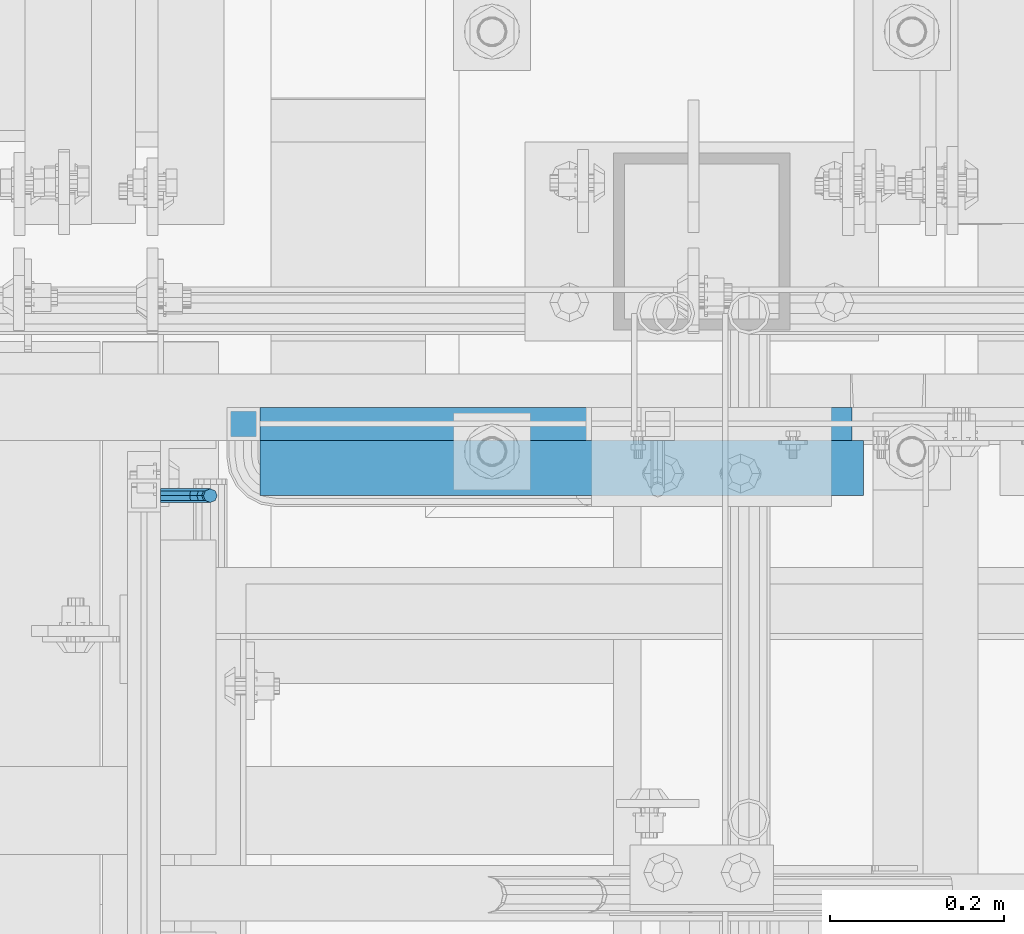
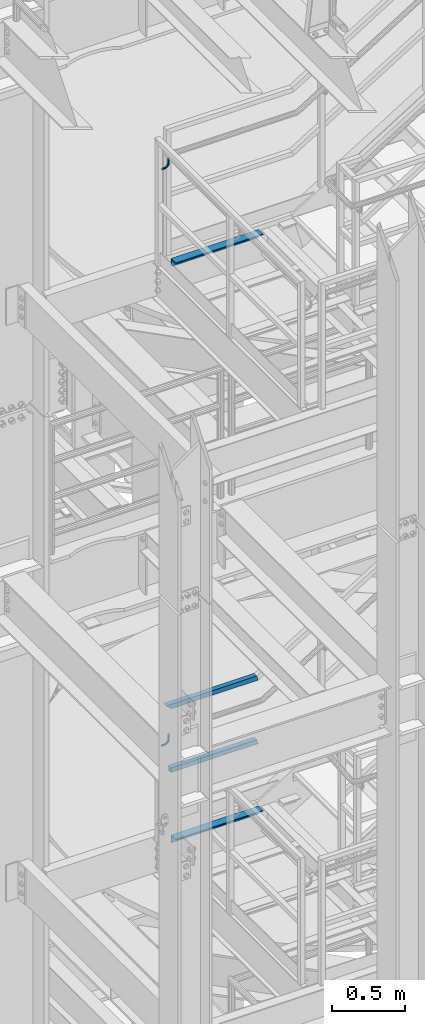
# One storey, part 1164 of 1876: 6 beams, 5 elements without a shape of their own.
"""IFC2X3 building model written with IfcOpenShell, lengths in millimetres."""

import ifcopenshell
import ifcopenshell.guid

model = None  # the IFC model being written
_history = None  # IfcOwnerHistory: only IFC2X3 demands one
_inside = {}  # id of a spatial element -> (the spatial element, [elements in it])
_under = {}  # id of a project, library or spatial element -> (it, [spatial elements below it])
_declared = {}  # id of a project -> (the project, [libraries it declares])
_typed = {}  # id of a type object -> (the type object, [elements of that type])
_made_of = {}  # id of a material, layer set ... -> (it, [elements and type objects made of it])


def new_model(schema):
    """Start an empty IFC model of exactly this schema.

    Asked for "IFC4X3", IfcOpenShell would pick the latest addendum, in which some entities
    have other attributes; the version numbers below select the first issue.
    IFC2X3 requires an IfcOwnerHistory on every rooted entity: one is made here for all.
    """
    global model, _history
    if schema == "IFC4X3":
        model = ifcopenshell.file(schema_version=(4, 3, 0, 0))
    else:
        model = ifcopenshell.file(schema=schema)
    _inside.clear()
    _under.clear()
    _declared.clear()
    _typed.clear()
    _made_of.clear()
    _history = None
    if model.schema == "IFC2X3":
        org = make("IfcOrganization", Name="unknown")
        user = make(
            "IfcPersonAndOrganization",
            ThePerson=make("IfcPerson", FamilyName="unknown"),
            TheOrganization=org,
        )
        app = make(
            "IfcApplication",
            ApplicationDeveloper=org,
            Version="unknown",
            ApplicationFullName="unknown",
            ApplicationIdentifier="unknown",
        )
        _history = make(
            "IfcOwnerHistory",
            OwningUser=user,
            OwningApplication=app,
            ChangeAction="ADDED",
            CreationDate=0,
        )
    return model


def make(cls, **values):
    """One entity of the class cls with the attributes given. An attribute that is None is left unset."""
    return model.create_entity(
        cls, **{name: value for name, value in values.items() if value is not None}
    )


def rooted(cls, **values):
    """An entity with a GlobalId (a new one), such as an element, a storey or a relation."""
    return make(cls, GlobalId=ifcopenshell.guid.new(), OwnerHistory=_history, **values)


def si_unit(unit_type, name, prefix=None):
    """IfcSIUnit, for example si_unit("LENGTHUNIT", "METRE", prefix="MILLI")."""
    return make("IfcSIUnit", UnitType=unit_type, Prefix=prefix, Name=name)


def assignment(units):
    """IfcUnitAssignment: the units of a project."""
    return None if units is None else make("IfcUnitAssignment", Units=units)


def point(xyz):
    """IfcCartesianPoint."""
    return None if xyz is None else make("IfcCartesianPoint", Coordinates=xyz)


def direction(xyz):
    """IfcDirection."""
    return None if xyz is None else make("IfcDirection", DirectionRatios=xyz)


def frame(location, z_axis=None, x_axis=None):
    """IfcAxis2Placement3D, a coordinate frame: its origin and axes. An axis left out is left unset."""
    return make(
        "IfcAxis2Placement3D",
        Location=point(location),
        Axis=direction(z_axis),
        RefDirection=direction(x_axis),
    )


def origin_with_axes():
    """The frame at (0, 0, 0) with the z axis (0, 0, 1) and the x axis (1, 0, 0) written out."""
    return frame((0.0, 0.0, 0.0), z_axis=(0.0, 0.0, 1.0), x_axis=(1.0, 0.0, 0.0))


def place(relative_to, where):
    """IfcLocalPlacement: puts the frame where relative to a parent placement (None: the world)."""
    return make(
        "IfcLocalPlacement", PlacementRelTo=relative_to, RelativePlacement=where
    )


def context(
    kind, dimensions, precision=None, world=None, true_north=None, identifier=None
):
    """IfcGeometricRepresentationContext, for example the 3D "Model" context."""
    return make(
        "IfcGeometricRepresentationContext",
        ContextIdentifier=identifier,
        ContextType=kind,
        CoordinateSpaceDimension=dimensions,
        Precision=precision,
        WorldCoordinateSystem=world,
        TrueNorth=true_north,
    )


def subcontext(parent, identifier, kind, view, scale=None):
    """IfcGeometricRepresentationSubContext, for example "Body" below "Model"."""
    return make(
        "IfcGeometricRepresentationSubContext",
        ContextIdentifier=identifier,
        ContextType=kind,
        ParentContext=parent,
        TargetScale=scale,
        TargetView=view,
    )


def project(units=None, contexts=None):
    """IfcProject with its units and contexts."""
    return rooted(
        "IfcProject",
        Name="project",
        RepresentationContexts=contexts,
        UnitsInContext=assignment(units),
    )


def spatial(cls, under=None, at=None, **own):
    """A site, building, storey or space (cls), placed at a placement, below another one or the project."""
    s = rooted(cls, ObjectPlacement=at, **own)
    if under is not None:
        _under.setdefault(under.id(), (under, []))[1].append(s)
    return s


def faces_of(points, faces, orient=None, outer=None):
    """IfcFace entities. A face is a list of loops; a loop is a list of indices into points, from 0.

    orient and outer hold one flag for each loop. By default every Orientation is true, the
    first loop of a face is its IfcFaceOuterBound and the others are IfcFaceBound.
    """
    made = []
    for i, loops in enumerate(faces):
        bounds = []
        for j, loop in enumerate(loops):
            is_outer = j == 0 if outer is None else outer[i][j]
            bounds.append(
                make(
                    "IfcFaceOuterBound" if is_outer else "IfcFaceBound",
                    Bound=make("IfcPolyLoop", Polygon=[points[k] for k in loop]),
                    Orientation=True if orient is None else orient[i][j],
                )
            )
        made.append(make("IfcFace", Bounds=bounds))
    return made


def faceted_brep(points, faces, orient=None, outer=None, voids=None):
    """IfcFacetedBrep: a solid bounded by flat faces; with voids (closed shells), ...WithVoids."""
    shared = [point(p) for p in points]
    hull = make("IfcClosedShell", CfsFaces=faces_of(shared, faces, orient, outer))
    if voids is None:
        return make("IfcFacetedBrep", Outer=hull)
    return make(
        "IfcFacetedBrepWithVoids",
        Outer=hull,
        Voids=[
            make(cls, CfsFaces=faces_of(shared, fs, o, b)) for cls, fs, o, b in voids
        ],
    )


def shape(context_of_items, identifier, shape_type, items):
    """IfcShapeRepresentation: the items that make up one representation, for example the "Body"."""
    return make(
        "IfcShapeRepresentation",
        ContextOfItems=context_of_items,
        RepresentationIdentifier=identifier,
        RepresentationType=shape_type,
        Items=items,
    )


def material(Name=None, Category=None):
    """IfcMaterial."""
    return make("IfcMaterial", Name=Name, Category=Category)


def made_of(thing, what):
    """Note that an element or type object is made of a material, layer set ...; save() writes the relation."""
    if what is not None:
        _made_of.setdefault(what.id(), (what, []))[1].append(thing)
    return thing


def type_object(cls, material=None, **own):
    """A type object (cls), such as IfcWallType, which elements share."""
    return made_of(rooted(cls, **own), material)


def element(
    cls,
    number,
    at=None,
    inside=None,
    cuts=None,
    type_object=None,
    material=None,
    context=None,
    identifier="Body",
    shape_type=None,
    held_by="IfcProductDefinitionShape",
    body=None,
    shapes=None,
    **own,
):
    """One element of the class cls, such as IfcWall. Its Tag is "e" and its number.

    at: its placement. inside: the storey or other place that contains it. cuts: it is an
    opening in that element (IfcRelVoidsElement). A single representation is given by context,
    identifier, shape_type and body (its items); several are given by shapes. held_by: the class
    of the entity that holds the representations. save() writes the other relations.
    """
    e = rooted(cls, Tag="e%d" % number, ObjectPlacement=at, **own)
    if body is not None:
        shapes = [shape(context, identifier, shape_type, body)]
    if shapes is not None:
        e.Representation = make(held_by, Representations=shapes)
    if inside is not None:
        _inside.setdefault(inside.id(), (inside, []))[1].append(e)
    if cuts is not None:
        rooted(
            "IfcRelVoidsElement", RelatingBuildingElement=cuts, RelatedOpeningElement=e
        )
    if type_object is not None:
        _typed.setdefault(type_object.id(), (type_object, []))[1].append(e)
    return made_of(e, material)


def aggregate(whole, parts):
    """IfcRelAggregates: a whole, such as a stair, and the parts it consists of."""
    return rooted("IfcRelAggregates", RelatingObject=whole, RelatedObjects=parts)


def save(model, path):
    """Write the relations noted so far, then the file.

    IfcRelAggregates (storeys below a building ...), IfcRelContainedInSpatialStructure (elements
    in a storey), IfcRelDefinesByType, IfcRelAssociatesMaterial and IfcRelDeclares: one each for
    every whole, place, type object, material and project.
    """
    for whole, parts in _under.values():
        aggregate(whole, parts)
    for where, things in _inside.values():
        rooted(
            "IfcRelContainedInSpatialStructure",
            RelatedElements=things,
            RelatingStructure=where,
        )
    for kind, things in _typed.values():
        rooted("IfcRelDefinesByType", RelatedObjects=things, RelatingType=kind)
    for what, things in _made_of.values():
        rooted("IfcRelAssociatesMaterial", RelatedObjects=things, RelatingMaterial=what)
    for by, libraries in _declared.values():
        rooted("IfcRelDeclares", RelatingContext=by, RelatedDefinitions=libraries)
    model.write(path)


model = new_model("IFC2X3")

# Units and contexts
model_context = context("Model", 3, precision=1e-05, world=origin_with_axes())
body_context = subcontext(model_context, "Body", "Model", "MODEL_VIEW")
ifc_project = project(units=[si_unit("LENGTHUNIT", "METRE", prefix="MILLI"), si_unit("AREAUNIT", "SQUARE_METRE"), si_unit("VOLUMEUNIT", "CUBIC_METRE"), si_unit("MASSUNIT", "GRAM", prefix="KILO"), si_unit("TIMEUNIT", "SECOND"), si_unit("PLANEANGLEUNIT", "RADIAN"), si_unit("SOLIDANGLEUNIT", "STERADIAN"), si_unit("THERMODYNAMICTEMPERATUREUNIT", "DEGREE_CELSIUS"), si_unit("LUMINOUSINTENSITYUNIT", "LUMEN")], contexts=[model_context])

# Site, building, storey
site_placement = place(None, origin_with_axes())
site = spatial("IfcSite", under=ifc_project, at=site_placement, CompositionType="ELEMENT")
building_placement = place(site_placement, origin_with_axes())
building = spatial("IfcBuilding", under=site, at=building_placement, Name="Undefined", CompositionType="ELEMENT")
storey_placement = place(building_placement, origin_with_axes())
storey = spatial("IfcBuildingStorey", under=building, at=storey_placement, Name="Undefined", CompositionType="ELEMENT", Elevation=0.0)

# Assembly, beam
assembly_1_placement = place(storey_placement, origin_with_axes())
assembly_1 = element("IfcElementAssembly", 1, at=assembly_1_placement, inside=storey, Name="STRINGER", AssemblyPlace="NOTDEFINED", PredefinedType="RIGID_FRAME")
ifc_material_1 = material(Name="STEEL/A36")
beam_type_1 = type_object("IfcBeamType", Name="L2-1/2X2-1/2X1/4", PredefinedType="NOTDEFINED")
beam_1_placement = place(assembly_1_placement, frame((1219.2, -4832.35000114587, 15531.2768518519), z_axis=(0.0, -1.0, 0.0), x_axis=(1.0, 0.0, 0.0)))
beam_1 = element("IfcBeam", 2, at=beam_1_placement, type_object=beam_type_1, material=ifc_material_1, Name="ANGLE", ObjectType="L2-1/2X2-1/2X1/4", context=body_context, shape_type="Brep", body=[
    faceted_brep([(0.0, 31.75, -31.75), (0.0, 31.75, 31.75), (693.737500000002, 31.75, 31.75), (693.737500000002, 31.75, -31.75), (0.0, 25.3999999999996, 31.75), (693.737500000002, 25.3999999999996, 31.75), (0.0, 25.3999999999996, -25.3999999999996), (693.737500000002, 25.3999999999996, -25.3999999999996), (0.0, -31.75, -25.3999999999996), (693.737500000002, -31.75, -25.3999999999996), (0.0, -31.75, -31.75), (693.737500000002, -31.75, -31.75)], [[[0, 1, 2, 3]], [[1, 4, 5, 2]], [[4, 6, 7, 5]], [[6, 8, 9, 7]], [[8, 10, 11, 9]], [[10, 0, 3, 11]], [[5, 7, 9, 11, 3, 2]], [[10, 8, 6, 4, 1, 0]]]),
])
aggregate(assembly_1, [beam_1])

assembly_2_placement = place(storey_placement, origin_with_axes())
assembly_2 = element("IfcElementAssembly", 3, at=assembly_2_placement, inside=storey, Name="STRINGER", AssemblyPlace="NOTDEFINED", PredefinedType="RIGID_FRAME")
beam_2_placement = place(assembly_2_placement, frame((1219.20000034225, -4832.35000114536, 10702.925), z_axis=(0.0, -1.0, 0.0), x_axis=(1.0, 0.0, 0.0)))
beam_2 = element("IfcBeam", 4, at=beam_2_placement, type_object=beam_type_1, material=ifc_material_1, Name="ANGLE", ObjectType="L2-1/2X2-1/2X1/4", context=body_context, shape_type="Brep", body=[
    faceted_brep([(0.0, 31.75, -31.75), (0.0, 31.75, 31.75), (693.737500000002, 31.75, 31.75), (693.737500000002, 31.75, -31.75), (0.0, 25.3999999999996, 31.75), (693.737500000002, 25.3999999999996, 31.75), (0.0, 25.3999999999996, -25.3999999999996), (693.737500000002, 25.3999999999996, -25.3999999999996), (0.0, -31.75, -25.3999999999996), (693.737500000002, -31.75, -25.3999999999996), (0.0, -31.75, -31.75), (693.737500000002, -31.75, -31.75)], [[[0, 1, 2, 3]], [[1, 4, 5, 2]], [[4, 6, 7, 5]], [[6, 8, 9, 7]], [[8, 10, 11, 9]], [[10, 0, 3, 11]], [[5, 7, 9, 11, 3, 2]], [[10, 8, 6, 4, 1, 0]]]),
])
aggregate(assembly_2, [beam_2])

# Assembly, beams
assembly_3_placement = place(storey_placement, origin_with_axes())
assembly_3 = element("IfcElementAssembly", 5, at=assembly_3_placement, inside=storey, Name="RAIL", AssemblyPlace="NOTDEFINED", PredefinedType="RIGID_FRAME")
ifc_material_2 = material()
beam_type_2 = type_object("IfcBeamType", Name="HSS1-1/2X1-1/2X1/8", PredefinedType="NOTDEFINED")
beam_3_placement = place(assembly_3_placement, frame((1181.10000111505, -4781.55000114554, 11274.4249989614), z_axis=(0.0, 0.0, 1.0), x_axis=(1.0, 0.0, 0.0)))
beam_3 = element("IfcBeam", 6, at=beam_3_placement, type_object=beam_type_2, material=ifc_material_2, Name="RAIL", ObjectType="HSS1-1/2X1-1/2X1/8", context=body_context, shape_type="Brep", body=[
    faceted_brep([(38.0999984689179, 15.8749992829999, -15.8749992829999), (38.0999984689179, -15.8749992829999, -15.8749992829999), (728.391843509154, -15.8749992829999, -15.8749992829999), (728.391843509154, 15.8749992829999, -15.8749992829999), (38.0999984689179, -15.8749992829999, 15.8749992829999), (719.408153656982, -15.8749992829999, 15.8749992829999), (38.0999984689179, 15.8749992829999, 15.8749992829999), (719.408153656982, 15.8749992829999, 15.8749992829999), (38.0999984689179, 19.0499992349996, -19.0499992350001), (38.0999984699993, 19.0499992349996, 19.0499992350001), (718.509784644771, 19.0499992349996, 19.0499992349996), (729.290212521365, 19.0499992349996, -19.0499992349996), (38.0999984699993, -19.0499992349996, 19.0499992350001), (718.509784644771, -19.0499992349996, 19.0499992349996), (38.0999984689179, -19.0499992349996, -19.0499992350001), (729.290212521365, -19.0499992349996, -19.0499992349996)], [[[0, 1, 2, 3]], [[1, 4, 5, 2]], [[4, 6, 7, 5]], [[6, 0, 3, 7]], [[8, 9, 10, 11]], [[9, 12, 13, 10]], [[12, 14, 15, 13]], [[14, 8, 11, 15]], [[13, 15, 11, 10], [5, 7, 3, 2]], [[14, 12, 9, 8], [6, 4, 1, 0]]]),
])
beam_4_placement = place(assembly_3_placement, frame((1904.99999969932, -4781.55000114554, 11807.8249989614), z_axis=(0.0, 0.0, -1.0), x_axis=(-1.0, 0.0, 0.0)))
beam_4 = element("IfcBeam", 7, at=beam_4_placement, type_object=beam_type_2, material=ifc_material_2, Name="RAIL", ObjectType="HSS1-1/2X1-1/2X1/8", context=body_context, shape_type="Brep", body=[
    faceted_brep([(4.49184492398945, 15.8749992829999, -15.8749992829999), (4.49184492398945, -15.8749992829999, -15.8749992829999), (720.724998632358, -15.8749992829999, -15.8749992829999), (720.724998632358, 15.8749992829999, -15.8749992829999), (-4.49184492818313, -15.8749992829999, 15.8749992829999), (688.975000066358, -15.8749992829999, 15.8749992829999), (-4.49184492818313, 15.8749992829999, 15.8749992829999), (688.975000066358, 15.8749992829999, 15.8749992829999), (5.39021393619987, 19.0499992349996, -19.0499992349996), (-5.39021394039355, 19.0499992349996, 19.0499992349996), (685.800000114358, 19.0499992349996, 19.0499992349996), (723.899998584358, 19.0499992349996, -19.0499992349996), (-5.39021394039355, -19.0499992349996, 19.0499992349996), (685.800000114358, -19.0499992349996, 19.0499992349996), (5.39021393619987, -19.0499992349996, -19.0499992349996), (723.899998584358, -19.0499992349996, -19.0499992349996)], [[[0, 1, 2, 3]], [[1, 4, 5, 2]], [[4, 6, 7, 5]], [[6, 0, 3, 7]], [[8, 9, 10, 11]], [[9, 12, 13, 10]], [[12, 14, 15, 13]], [[14, 8, 11, 15]], [[13, 15, 11, 10], [5, 7, 3, 2]], [[14, 12, 9, 8], [6, 4, 1, 0]]]),
])
aggregate(assembly_3, [beam_3, beam_4])

# Assembly, beam
assembly_4_placement = place(storey_placement, origin_with_axes())
assembly_4 = element("IfcElementAssembly", 8, at=assembly_4_placement, inside=storey, Name="RAIL", AssemblyPlace="NOTDEFINED", PredefinedType="RIGID_FRAME")
beam_type_3 = type_object("IfcBeamType", PredefinedType="NOTDEFINED")
beam_5_placement = place(assembly_4_placement, frame((1104.89999922875, -4864.10000191087, 16388.4316082526), z_axis=(0.0, -1.0, 0.0), x_axis=(1.0, 0.0, 0.0)))
beam_5 = element("IfcBeam", 9, at=beam_5_placement, type_object=beam_type_3, material=ifc_material_1, Name="BRACKET", context=body_context, shape_type="Brep", body=[
    faceted_brep([(0.0, -7.9375, 0.0), (0.0, -5.61266007566822, -5.61266007566883), (23.8125, -5.61266007566883, -5.61266007566792), (23.8125, -7.9375, 0.0), (0.0, 0.0, -7.9375), (23.8125, 0.0, -7.9375), (0.0, 5.61266007566822, -5.61266007566883), (23.8125, 5.61266007566883, -5.61266007566792), (0.0, 7.9375, 0.0), (23.8125, 7.9375, 0.0), (0.0, 5.61266007566822, 5.61266007566883), (23.8125, 5.61266007566883, 5.61266007566792), (0.0, 0.0, 7.9375), (23.8125, 0.0, 7.9375), (0.0, -5.61266007566822, 5.61266007566883), (23.8125, -5.61266007566883, 5.61266007566792), (39.6077592547981, -4.79562758825341, 0.0), (38.7180815328556, -2.64775556579843, 5.61266007566792), (36.5702095103998, 2.53766620105671, 7.9375), (34.4223374879448, 7.72308796790821, 5.61266007566792), (33.5326597660023, 9.87095999036319, 0.0), (34.4223374879448, 7.72308796790821, -5.61266007566792), (36.5702095103998, 2.53766620105671, -7.9375), (38.7180815328556, -2.64775556579843, -5.61266007566792), (51.3544233967659, 5.79557812911298, -5.61266007566792), (52.9983334724348, 4.15166805344415, 0.0), (47.3856733967659, 9.76432812911298, -7.9375), (43.4169233967659, 13.733078129113, -5.61266007566792), (41.773013321098, 15.3769882047818, 0.0), (43.4169233967659, 13.733078129113, 5.61266007566792), (47.3856733967659, 9.76432812911298, 7.9375), (51.3544233967659, 5.79557812911298, 5.61266007566792), (59.7977570916764, 18.4319199930251, -5.61266007566792), (61.9456291141314, 17.5422422710835, 0.0), (54.6123353248231, 20.5797920154801, -7.9375), (49.4269135579698, 22.727664037935, -5.61266007566792), (47.2790415355148, 23.6173417598766, 0.0), (49.4269135579698, 22.727664037935, 5.61266007566792), (54.6123353248231, 20.5797920154801, 7.9375), (59.7977570916764, 18.4319199930251, 5.61266007566792), (62.7626616015468, 33.3375015258789, -5.61266007566792), (65.0875015258789, 33.3375015258789, 0.0), (57.1500015258789, 33.3375015258789, -7.9375), (51.5373414502101, 33.3375015258789, -5.61266007566792), (49.2125015258789, 33.3375015258789, 0.0), (51.5373414502101, 33.3375015258789, 5.61266007566792), (57.1500015258789, 33.3375015258789, 7.9375), (62.7626616015468, 33.3375015258789, 5.61266007566792), (62.7626616015468, 76.1999969482422, -5.61266007566792), (65.0875015258789, 76.1999969482422, 0.0), (57.1500015258789, 76.1999969482422, -7.9375), (51.537341450211, 76.1999969482422, -5.61266007566792), (49.2125015258789, 76.1999969482422, 0.0), (51.537341450211, 76.1999969482422, 5.61266007566792), (57.1500015258789, 76.1999969482422, 7.9375), (62.7626616015468, 76.1999969482422, 5.61266007566792)], [[[0, 1, 2, 3]], [[1, 4, 5, 2]], [[4, 6, 7, 5]], [[6, 8, 9, 7]], [[8, 10, 11, 9]], [[10, 12, 13, 11]], [[12, 14, 15, 13]], [[14, 0, 3, 15]], [[14, 12, 10, 8, 6, 4, 1, 0]], [[15, 3, 16, 17]], [[13, 15, 17, 18]], [[11, 13, 18, 19]], [[9, 11, 19, 20]], [[7, 9, 20, 21]], [[5, 7, 21, 22]], [[2, 5, 22, 23]], [[3, 2, 23, 16]], [[23, 24, 25, 16]], [[22, 26, 24, 23]], [[21, 27, 26, 22]], [[20, 28, 27, 21]], [[19, 29, 28, 20]], [[18, 30, 29, 19]], [[17, 31, 30, 18]], [[16, 25, 31, 17]], [[24, 32, 33, 25]], [[26, 34, 32, 24]], [[27, 35, 34, 26]], [[28, 36, 35, 27]], [[29, 37, 36, 28]], [[30, 38, 37, 29]], [[31, 39, 38, 30]], [[25, 33, 39, 31]], [[32, 40, 41, 33]], [[34, 42, 40, 32]], [[35, 43, 42, 34]], [[36, 44, 43, 35]], [[37, 45, 44, 36]], [[38, 46, 45, 37]], [[39, 47, 46, 38]], [[33, 41, 47, 39]], [[41, 40, 48, 49]], [[40, 42, 50, 48]], [[42, 43, 51, 50]], [[43, 44, 52, 51]], [[44, 45, 53, 52]], [[45, 46, 54, 53]], [[46, 47, 55, 54]], [[47, 41, 49, 55]], [[50, 51, 52, 53, 54, 55, 49, 48]]]),
])
aggregate(assembly_4, [beam_5])

assembly_5_placement = place(storey_placement, origin_with_axes())
assembly_5 = element("IfcElementAssembly", 10, at=assembly_5_placement, inside=storey, Name="RAIL", AssemblyPlace="NOTDEFINED", PredefinedType="RIGID_FRAME")
beam_6_placement = place(assembly_5_placement, frame((1104.89999957726, -4864.10000191036, 11560.0797565027), z_axis=(0.0, -1.0, 0.0), x_axis=(1.0, 0.0, 0.0)))
beam_6 = element("IfcBeam", 11, at=beam_6_placement, type_object=beam_type_3, material=ifc_material_1, Name="BRACKET", context=body_context, shape_type="Brep", body=[
    faceted_brep([(0.0, -7.9375, 0.0), (0.0, -5.61266007566822, -5.61266007566883), (23.8125, -5.61266007566883, -5.61266007566792), (23.8125, -7.9375, 0.0), (0.0, 0.0, -7.9375), (23.8125, 0.0, -7.9375), (0.0, 5.61266007566822, -5.61266007566883), (23.8125, 5.61266007566883, -5.61266007566792), (0.0, 7.9375, 0.0), (23.8125, 7.9375, 0.0), (0.0, 5.61266007566822, 5.61266007566883), (23.8125, 5.61266007566883, 5.61266007566792), (0.0, 0.0, 7.9375), (23.8125, 0.0, 7.9375), (0.0, -5.61266007566822, 5.61266007566883), (23.8125, -5.61266007566883, 5.61266007566792), (39.6077592547981, -4.79562758825341, 0.0), (38.7180815328556, -2.64775556579843, 5.61266007566792), (36.5702095103998, 2.53766620105671, 7.9375), (34.4223374879448, 7.72308796790821, 5.61266007566792), (33.5326597660023, 9.87095999036319, 0.0), (34.4223374879448, 7.72308796790821, -5.61266007566792), (36.5702095103998, 2.53766620105671, -7.9375), (38.7180815328556, -2.64775556579843, -5.61266007566792), (51.3544233967659, 5.79557812911298, -5.61266007566792), (52.9983334724348, 4.15166805344415, 0.0), (47.3856733967659, 9.76432812911298, -7.9375), (43.4169233967659, 13.733078129113, -5.61266007566792), (41.773013321098, 15.3769882047818, 0.0), (43.4169233967659, 13.733078129113, 5.61266007566792), (47.3856733967659, 9.76432812911298, 7.9375), (51.3544233967659, 5.79557812911298, 5.61266007566792), (59.7977570916764, 18.4319199930251, -5.61266007566792), (61.9456291141314, 17.5422422710835, 0.0), (54.6123353248231, 20.5797920154801, -7.9375), (49.4269135579698, 22.727664037935, -5.61266007566792), (47.2790415355148, 23.6173417598766, 0.0), (49.4269135579698, 22.727664037935, 5.61266007566792), (54.6123353248231, 20.5797920154801, 7.9375), (59.7977570916764, 18.4319199930251, 5.61266007566792), (62.7626616015468, 33.3375015258789, -5.61266007566792), (65.0875015258789, 33.3375015258789, 0.0), (57.1500015258789, 33.3375015258789, -7.9375), (51.5373414502101, 33.3375015258789, -5.61266007566792), (49.2125015258789, 33.3375015258789, 0.0), (51.5373414502101, 33.3375015258789, 5.61266007566792), (57.1500015258789, 33.3375015258789, 7.9375), (62.7626616015468, 33.3375015258789, 5.61266007566792), (62.7626616015468, 76.1999969482422, -5.61266007566792), (65.0875015258789, 76.1999969482422, 0.0), (57.1500015258789, 76.1999969482422, -7.9375), (51.537341450211, 76.1999969482422, -5.61266007566792), (49.2125015258789, 76.1999969482422, 0.0), (51.537341450211, 76.1999969482422, 5.61266007566792), (57.1500015258789, 76.1999969482422, 7.9375), (62.7626616015468, 76.1999969482422, 5.61266007566792)], [[[0, 1, 2, 3]], [[1, 4, 5, 2]], [[4, 6, 7, 5]], [[6, 8, 9, 7]], [[8, 10, 11, 9]], [[10, 12, 13, 11]], [[12, 14, 15, 13]], [[14, 0, 3, 15]], [[14, 12, 10, 8, 6, 4, 1, 0]], [[15, 3, 16, 17]], [[13, 15, 17, 18]], [[11, 13, 18, 19]], [[9, 11, 19, 20]], [[7, 9, 20, 21]], [[5, 7, 21, 22]], [[2, 5, 22, 23]], [[3, 2, 23, 16]], [[23, 24, 25, 16]], [[22, 26, 24, 23]], [[21, 27, 26, 22]], [[20, 28, 27, 21]], [[19, 29, 28, 20]], [[18, 30, 29, 19]], [[17, 31, 30, 18]], [[16, 25, 31, 17]], [[24, 32, 33, 25]], [[26, 34, 32, 24]], [[27, 35, 34, 26]], [[28, 36, 35, 27]], [[29, 37, 36, 28]], [[30, 38, 37, 29]], [[31, 39, 38, 30]], [[25, 33, 39, 31]], [[32, 40, 41, 33]], [[34, 42, 40, 32]], [[35, 43, 42, 34]], [[36, 44, 43, 35]], [[37, 45, 44, 36]], [[38, 46, 45, 37]], [[39, 47, 46, 38]], [[33, 41, 47, 39]], [[41, 40, 48, 49]], [[40, 42, 50, 48]], [[42, 43, 51, 50]], [[43, 44, 52, 51]], [[44, 45, 53, 52]], [[45, 46, 54, 53]], [[46, 47, 55, 54]], [[47, 41, 49, 55]], [[50, 51, 52, 53, 54, 55, 49, 48]]]),
])
aggregate(assembly_5, [beam_6])

save(model, "model.ifc")
